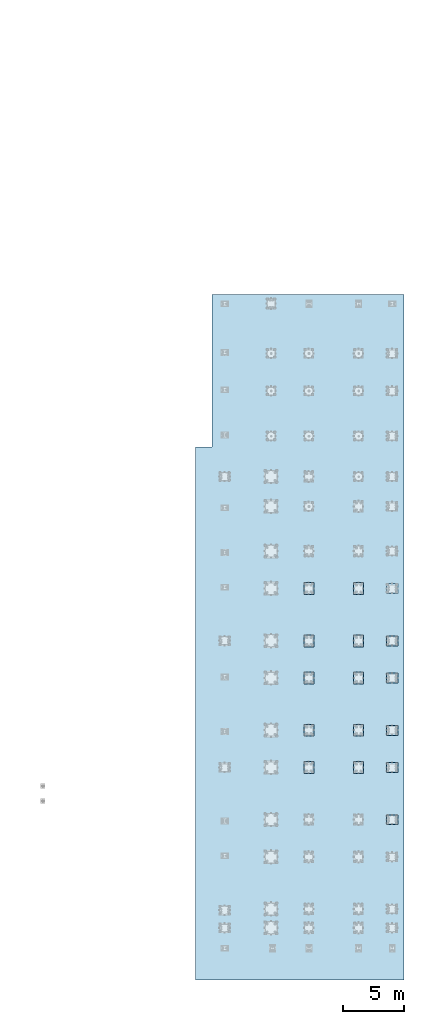
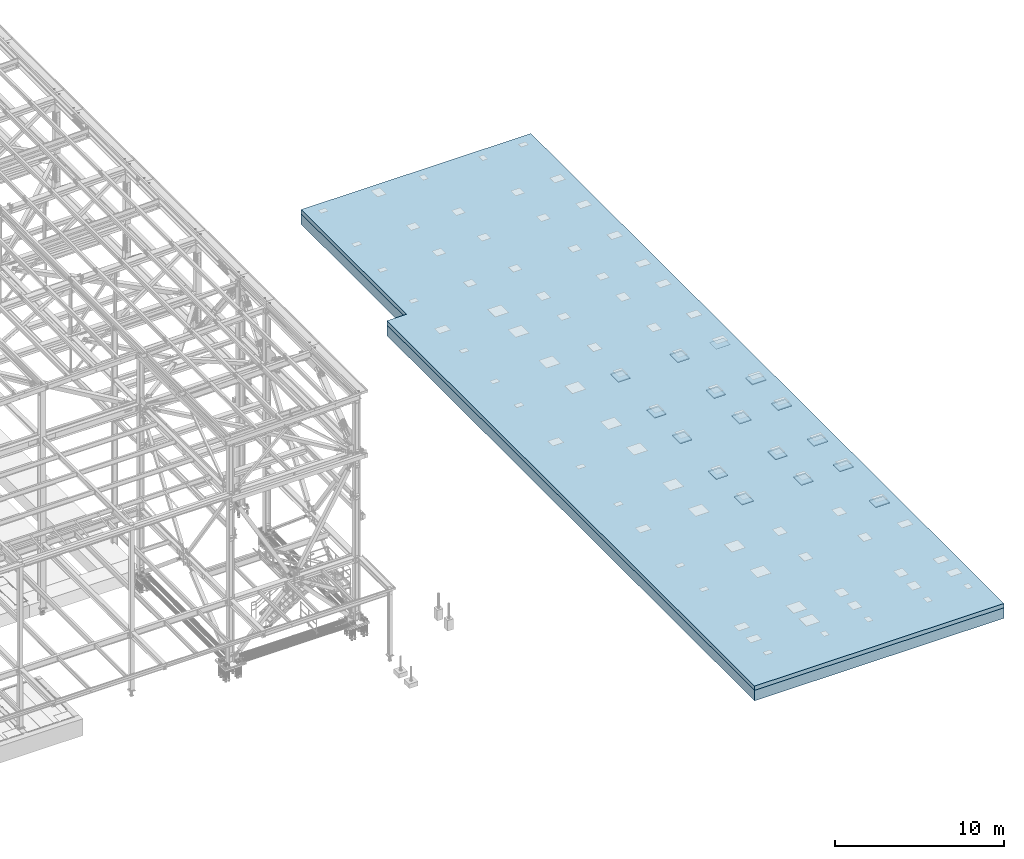
# One storey, part 3001 of 3843: 31 plates, 2 slabs, 33 elements without a shape of their own.
"""IFC2X3 building model written with IfcOpenShell, lengths in millimetres."""

from ifc_helpers import new_model, si_unit, frame, origin_with_axes, place, context, subcontext, project, spatial, faceted_brep, material, type_object, element, aggregate, save


model = new_model("IFC2X3")

# Units and contexts
model_context = context("Model", 3, precision=1e-05, world=origin_with_axes())
body_context = subcontext(model_context, "Body", "Model", "MODEL_VIEW")
ifc_project = project(units=[si_unit("LENGTHUNIT", "METRE", prefix="MILLI"), si_unit("AREAUNIT", "SQUARE_METRE"), si_unit("VOLUMEUNIT", "CUBIC_METRE"), si_unit("MASSUNIT", "GRAM", prefix="KILO"), si_unit("TIMEUNIT", "SECOND"), si_unit("PLANEANGLEUNIT", "RADIAN"), si_unit("SOLIDANGLEUNIT", "STERADIAN"), si_unit("THERMODYNAMICTEMPERATUREUNIT", "DEGREE_CELSIUS"), si_unit("LUMINOUSINTENSITYUNIT", "LUMEN")], contexts=[model_context])

# Site, building, storey
site_placement = place(None, origin_with_axes())
site = spatial("IfcSite", under=ifc_project, at=site_placement, CompositionType="ELEMENT")
building_placement = place(site_placement, origin_with_axes())
building = spatial("IfcBuilding", under=site, at=building_placement, Name="Undefined", CompositionType="ELEMENT")
storey_placement = place(building_placement, origin_with_axes())
storey = spatial("IfcBuildingStorey", under=building, at=storey_placement, Name="Undefined", CompositionType="ELEMENT", Elevation=0.0)

# Assembly, plate
assembly_1_placement = place(storey_placement, origin_with_axes())
assembly_1 = element("IfcElementAssembly", 1, at=assembly_1_placement, inside=storey, Name="TEMPLATE", AssemblyPlace="NOTDEFINED", PredefinedType="RIGID_FRAME")
ifc_material_1 = material(Name="STEEL/A572-50")
plate_type_1 = type_object("IfcPlateType", PredefinedType="NOTDEFINED")
plate_1_placement = place(assembly_1_placement, frame((119329.2, 29819.6, 29791.025), z_axis=(0.0, -1.0, 0.0), x_axis=(-1.0, 0.0, 0.0)))
plate_1 = element("IfcPlate", 2, at=plate_1_placement, type_object=plate_type_1, material=ifc_material_1, Name="TEMPLATE", context=body_context, shape_type="Brep", body=[
    faceted_brep([(0.0, -3.17499999999927, 0.0), (-1.45519152283669e-11, -3.17499999999927, 812.799999999945), (-1.45519152283669e-11, 3.17499999999927, 812.799999999945), (0.0, 3.17499999999927, 0.0), (965.199999999997, -3.17499999999927, 812.799999999974), (965.199999999997, 3.17499999999927, 812.799999999974), (965.199999999997, -3.17499999999927, 0.0), (965.199999999997, 3.17499999999927, 0.0)], [[[0, 1, 2, 3]], [[1, 4, 5, 2]], [[4, 6, 7, 5]], [[6, 0, 3, 7]], [[5, 7, 3, 2]], [[6, 4, 1, 0]]]),
])
aggregate(assembly_1, [plate_1])

assembly_2_placement = place(storey_placement, origin_with_axes())
assembly_2 = element("IfcElementAssembly", 3, at=assembly_2_placement, inside=storey, Name="TEMPLATE", AssemblyPlace="NOTDEFINED", PredefinedType="RIGID_FRAME")
plate_2_placement = place(assembly_2_placement, frame((119329.2, 25539.7, 29791.025), z_axis=(0.0, -1.0, 0.0), x_axis=(-1.0, 0.0, 0.0)))
plate_2 = element("IfcPlate", 4, at=plate_2_placement, type_object=plate_type_1, material=ifc_material_1, Name="TEMPLATE", context=body_context, shape_type="Brep", body=[
    faceted_brep([(0.0, -3.17499999999927, 0.0), (-1.45519152283669e-11, -3.17499999999927, 812.799999999945), (-1.45519152283669e-11, 3.17499999999927, 812.799999999945), (0.0, 3.17499999999927, 0.0), (965.199999999997, -3.17499999999927, 812.799999999974), (965.199999999997, 3.17499999999927, 812.799999999974), (965.199999999997, -3.17499999999927, 0.0), (965.199999999997, 3.17499999999927, 0.0)], [[[0, 1, 2, 3]], [[1, 4, 5, 2]], [[4, 6, 7, 5]], [[6, 0, 3, 7]], [[5, 7, 3, 2]], [[6, 4, 1, 0]]]),
])
aggregate(assembly_2, [plate_2])

assembly_3_placement = place(storey_placement, origin_with_axes())
assembly_3 = element("IfcElementAssembly", 5, at=assembly_3_placement, inside=storey, Name="TEMPLATE", AssemblyPlace="NOTDEFINED", PredefinedType="RIGID_FRAME")
plate_3_placement = place(assembly_3_placement, frame((119329.2, 22491.7, 29791.025), z_axis=(0.0, -1.0, 0.0), x_axis=(-1.0, 0.0, 0.0)))
plate_3 = element("IfcPlate", 6, at=plate_3_placement, type_object=plate_type_1, material=ifc_material_1, Name="TEMPLATE", context=body_context, shape_type="Brep", body=[
    faceted_brep([(0.0, -3.17499999999927, 0.0), (-1.45519152283669e-11, -3.17499999999927, 812.799999999945), (-1.45519152283669e-11, 3.17499999999927, 812.799999999945), (0.0, 3.17499999999927, 0.0), (965.199999999997, -3.17499999999927, 812.799999999974), (965.199999999997, 3.17499999999927, 812.799999999974), (965.199999999997, -3.17499999999927, 0.0), (965.199999999997, 3.17499999999927, 0.0)], [[[0, 1, 2, 3]], [[1, 4, 5, 2]], [[4, 6, 7, 5]], [[6, 0, 3, 7]], [[5, 7, 3, 2]], [[6, 4, 1, 0]]]),
])
aggregate(assembly_3, [plate_3])

assembly_4_placement = place(storey_placement, origin_with_axes())
assembly_4 = element("IfcElementAssembly", 7, at=assembly_4_placement, inside=storey, Name="TEMPLATE", AssemblyPlace="NOTDEFINED", PredefinedType="RIGID_FRAME")
plate_4_placement = place(assembly_4_placement, frame((119329.2, 18224.5, 29791.025), z_axis=(0.0, -1.0, 0.0), x_axis=(-1.0, 0.0, 0.0)))
plate_4 = element("IfcPlate", 8, at=plate_4_placement, type_object=plate_type_1, material=ifc_material_1, Name="TEMPLATE", context=body_context, shape_type="Brep", body=[
    faceted_brep([(0.0, -3.17499999999927, 0.0), (-1.45519152283669e-11, -3.17499999999927, 812.799999999945), (-1.45519152283669e-11, 3.17499999999927, 812.799999999945), (0.0, 3.17499999999927, 0.0), (965.199999999997, -3.17499999999927, 812.799999999974), (965.199999999997, 3.17499999999927, 812.799999999974), (965.199999999997, -3.17499999999927, 0.0), (965.199999999997, 3.17499999999927, 0.0)], [[[0, 1, 2, 3]], [[1, 4, 5, 2]], [[4, 6, 7, 5]], [[6, 0, 3, 7]], [[5, 7, 3, 2]], [[6, 4, 1, 0]]]),
])
aggregate(assembly_4, [plate_4])

assembly_5_placement = place(storey_placement, origin_with_axes())
assembly_5 = element("IfcElementAssembly", 9, at=assembly_5_placement, inside=storey, Name="TEMPLATE", AssemblyPlace="NOTDEFINED", PredefinedType="RIGID_FRAME")
plate_5_placement = place(assembly_5_placement, frame((119329.2, 15176.5, 29791.025), z_axis=(0.0, -1.0, 0.0), x_axis=(-1.0, 0.0, 0.0)))
plate_5 = element("IfcPlate", 10, at=plate_5_placement, type_object=plate_type_1, material=ifc_material_1, Name="TEMPLATE", context=body_context, shape_type="Brep", body=[
    faceted_brep([(0.0, -3.17499999999927, 0.0), (-1.45519152283669e-11, -3.17499999999927, 812.799999999945), (-1.45519152283669e-11, 3.17499999999927, 812.799999999945), (0.0, 3.17499999999927, 0.0), (965.199999999997, -3.17499999999927, 812.799999999974), (965.199999999997, 3.17499999999927, 812.799999999974), (965.199999999997, -3.17499999999927, 0.0), (965.199999999997, 3.17499999999927, 0.0)], [[[0, 1, 2, 3]], [[1, 4, 5, 2]], [[4, 6, 7, 5]], [[6, 0, 3, 7]], [[5, 7, 3, 2]], [[6, 4, 1, 0]]]),
])
aggregate(assembly_5, [plate_5])

assembly_6_placement = place(storey_placement, origin_with_axes())
assembly_6 = element("IfcElementAssembly", 11, at=assembly_6_placement, inside=storey, Name="TEMPLATE", AssemblyPlace="NOTDEFINED", PredefinedType="RIGID_FRAME")
plate_6_placement = place(assembly_6_placement, frame((119329.2, 10909.3, 29791.025), z_axis=(0.0, -1.0, 0.0), x_axis=(-1.0, 0.0, 0.0)))
plate_6 = element("IfcPlate", 12, at=plate_6_placement, type_object=plate_type_1, material=ifc_material_1, Name="TEMPLATE", context=body_context, shape_type="Brep", body=[
    faceted_brep([(0.0, -3.17499999999927, 0.0), (-1.45519152283669e-11, -3.17499999999927, 812.799999999945), (-1.45519152283669e-11, 3.17499999999927, 812.799999999945), (0.0, 3.17499999999927, 0.0), (965.199999999997, -3.17499999999927, 812.799999999974), (965.199999999997, 3.17499999999927, 812.799999999974), (965.199999999997, -3.17499999999927, 0.0), (965.199999999997, 3.17499999999927, 0.0)], [[[0, 1, 2, 3]], [[1, 4, 5, 2]], [[4, 6, 7, 5]], [[6, 0, 3, 7]], [[5, 7, 3, 2]], [[6, 4, 1, 0]]]),
])
aggregate(assembly_6, [plate_6])

assembly_7_placement = place(storey_placement, origin_with_axes())
assembly_7 = element("IfcElementAssembly", 13, at=assembly_7_placement, inside=storey, Name="TEMPLATE", AssemblyPlace="NOTDEFINED", PredefinedType="RIGID_FRAME")
ifc_material_2 = material(Name="STEEL/A36")
plate_7_placement = place(assembly_7_placement, frame((115697.0, 28930.6, 29791.025), z_axis=(0.0, 1.0, 0.0), x_axis=(1.0, 0.0, 0.0)))
plate_7 = element("IfcPlate", 14, at=plate_7_placement, type_object=plate_type_1, material=ifc_material_2, Name="TEMPLATE", context=body_context, shape_type="Brep", body=[
    faceted_brep([(0.0, -3.17499999999927, 0.0), (-4.36557456851006e-11, -3.17499999999927, 965.200000000004), (-4.36557456851006e-11, 3.17499999999927, 965.200000000004), (0.0, 3.17499999999927, 0.0), (812.799999999974, -3.17499999999927, 965.199999999997), (812.799999999974, 3.17499999999927, 965.199999999997), (812.800000000017, -3.17499999999927, 1.45519152283669e-11), (812.800000000017, 3.17499999999927, 1.45519152283669e-11)], [[[0, 1, 2, 3]], [[1, 4, 5, 2]], [[4, 6, 7, 5]], [[6, 0, 3, 7]], [[5, 7, 3, 2]], [[6, 4, 1, 0]]]),
])
aggregate(assembly_7, [plate_7])

assembly_8_placement = place(storey_placement, origin_with_axes())
assembly_8 = element("IfcElementAssembly", 15, at=assembly_8_placement, inside=storey, Name="TEMPLATE", AssemblyPlace="NOTDEFINED", PredefinedType="RIGID_FRAME")
plate_8_placement = place(assembly_8_placement, frame((115697.0, 24650.7, 29791.025), z_axis=(0.0, 1.0, 0.0), x_axis=(1.0, 0.0, 0.0)))
plate_8 = element("IfcPlate", 16, at=plate_8_placement, type_object=plate_type_1, material=ifc_material_2, Name="TEMPLATE", context=body_context, shape_type="Brep", body=[
    faceted_brep([(0.0, -3.17499999999927, 0.0), (-4.36557456851006e-11, -3.17499999999927, 965.200000000004), (-4.36557456851006e-11, 3.17499999999927, 965.200000000004), (0.0, 3.17499999999927, 0.0), (812.799999999974, -3.17499999999927, 965.199999999997), (812.799999999974, 3.17499999999927, 965.199999999997), (812.800000000017, -3.17499999999927, 1.45519152283669e-11), (812.800000000017, 3.17499999999927, 1.45519152283669e-11)], [[[0, 1, 2, 3]], [[1, 4, 5, 2]], [[4, 6, 7, 5]], [[6, 0, 3, 7]], [[5, 7, 3, 2]], [[6, 4, 1, 0]]]),
])
aggregate(assembly_8, [plate_8])

assembly_9_placement = place(storey_placement, origin_with_axes())
assembly_9 = element("IfcElementAssembly", 17, at=assembly_9_placement, inside=storey, Name="TEMPLATE", AssemblyPlace="NOTDEFINED", PredefinedType="RIGID_FRAME")
plate_9_placement = place(assembly_9_placement, frame((115697.0, 21602.7, 29791.025), z_axis=(0.0, 1.0, 0.0), x_axis=(1.0, 0.0, 0.0)))
plate_9 = element("IfcPlate", 18, at=plate_9_placement, type_object=plate_type_1, material=ifc_material_2, Name="TEMPLATE", context=body_context, shape_type="Brep", body=[
    faceted_brep([(0.0, -3.17499999999927, 0.0), (-4.36557456851006e-11, -3.17499999999927, 965.200000000004), (-4.36557456851006e-11, 3.17499999999927, 965.200000000004), (0.0, 3.17499999999927, 0.0), (812.799999999974, -3.17499999999927, 965.199999999997), (812.799999999974, 3.17499999999927, 965.199999999997), (812.800000000017, -3.17499999999927, 1.45519152283669e-11), (812.800000000017, 3.17499999999927, 1.45519152283669e-11)], [[[0, 1, 2, 3]], [[1, 4, 5, 2]], [[4, 6, 7, 5]], [[6, 0, 3, 7]], [[5, 7, 3, 2]], [[6, 4, 1, 0]]]),
])
aggregate(assembly_9, [plate_9])

assembly_10_placement = place(storey_placement, origin_with_axes())
assembly_10 = element("IfcElementAssembly", 19, at=assembly_10_placement, inside=storey, Name="TEMPLATE", AssemblyPlace="NOTDEFINED", PredefinedType="RIGID_FRAME")
plate_10_placement = place(assembly_10_placement, frame((115697.0, 17335.5, 29791.025), z_axis=(0.0, 1.0, 0.0), x_axis=(1.0, 0.0, 0.0)))
plate_10 = element("IfcPlate", 20, at=plate_10_placement, type_object=plate_type_1, material=ifc_material_2, Name="TEMPLATE", context=body_context, shape_type="Brep", body=[
    faceted_brep([(0.0, -3.17499999999927, 0.0), (-4.36557456851006e-11, -3.17499999999927, 965.200000000004), (-4.36557456851006e-11, 3.17499999999927, 965.200000000004), (0.0, 3.17499999999927, 0.0), (812.799999999974, -3.17499999999927, 965.199999999997), (812.799999999974, 3.17499999999927, 965.199999999997), (812.800000000017, -3.17499999999927, 1.45519152283669e-11), (812.800000000017, 3.17499999999927, 1.45519152283669e-11)], [[[0, 1, 2, 3]], [[1, 4, 5, 2]], [[4, 6, 7, 5]], [[6, 0, 3, 7]], [[5, 7, 3, 2]], [[6, 4, 1, 0]]]),
])
aggregate(assembly_10, [plate_10])

assembly_11_placement = place(storey_placement, origin_with_axes())
assembly_11 = element("IfcElementAssembly", 21, at=assembly_11_placement, inside=storey, Name="TEMPLATE", AssemblyPlace="NOTDEFINED", PredefinedType="RIGID_FRAME")
plate_11_placement = place(assembly_11_placement, frame((115697.0, 14287.5, 29791.025), z_axis=(0.0, 1.0, 0.0), x_axis=(1.0, 0.0, 0.0)))
plate_11 = element("IfcPlate", 22, at=plate_11_placement, type_object=plate_type_1, material=ifc_material_2, Name="TEMPLATE", context=body_context, shape_type="Brep", body=[
    faceted_brep([(0.0, -3.17499999999927, 0.0), (-4.36557456851006e-11, -3.17499999999927, 965.200000000004), (-4.36557456851006e-11, 3.17499999999927, 965.200000000004), (0.0, 3.17499999999927, 0.0), (812.799999999974, -3.17499999999927, 965.199999999997), (812.799999999974, 3.17499999999927, 965.199999999997), (812.800000000017, -3.17499999999927, 1.45519152283669e-11), (812.800000000017, 3.17499999999927, 1.45519152283669e-11)], [[[0, 1, 2, 3]], [[1, 4, 5, 2]], [[4, 6, 7, 5]], [[6, 0, 3, 7]], [[5, 7, 3, 2]], [[6, 4, 1, 0]]]),
])
aggregate(assembly_11, [plate_11])

assembly_12_placement = place(storey_placement, origin_with_axes())
assembly_12 = element("IfcElementAssembly", 23, at=assembly_12_placement, inside=storey, Name="TEMPLATE", AssemblyPlace="NOTDEFINED", PredefinedType="RIGID_FRAME")
plate_12_placement = place(assembly_12_placement, frame((111633.0, 28930.6, 29791.025), z_axis=(0.0, 1.0, 0.0), x_axis=(1.0, 0.0, 0.0)))
plate_12 = element("IfcPlate", 24, at=plate_12_placement, type_object=plate_type_1, material=ifc_material_2, Name="TEMPLATE", context=body_context, shape_type="Brep", body=[
    faceted_brep([(0.0, -3.17499999999927, 0.0), (-4.36557456851006e-11, -3.17499999999927, 965.200000000004), (-4.36557456851006e-11, 3.17499999999927, 965.200000000004), (0.0, 3.17499999999927, 0.0), (812.799999999974, -3.17499999999927, 965.199999999997), (812.799999999974, 3.17499999999927, 965.199999999997), (812.800000000017, -3.17499999999927, 1.45519152283669e-11), (812.800000000017, 3.17499999999927, 1.45519152283669e-11)], [[[0, 1, 2, 3]], [[1, 4, 5, 2]], [[4, 6, 7, 5]], [[6, 0, 3, 7]], [[5, 7, 3, 2]], [[6, 4, 1, 0]]]),
])
aggregate(assembly_12, [plate_12])

assembly_13_placement = place(storey_placement, origin_with_axes())
assembly_13 = element("IfcElementAssembly", 25, at=assembly_13_placement, inside=storey, Name="TEMPLATE", AssemblyPlace="NOTDEFINED", PredefinedType="RIGID_FRAME")
plate_13_placement = place(assembly_13_placement, frame((111633.0, 24650.7, 29791.025), z_axis=(0.0, 1.0, 0.0), x_axis=(1.0, 0.0, 0.0)))
plate_13 = element("IfcPlate", 26, at=plate_13_placement, type_object=plate_type_1, material=ifc_material_2, Name="TEMPLATE", context=body_context, shape_type="Brep", body=[
    faceted_brep([(0.0, -3.17499999999927, 0.0), (-4.36557456851006e-11, -3.17499999999927, 965.200000000004), (-4.36557456851006e-11, 3.17499999999927, 965.200000000004), (0.0, 3.17499999999927, 0.0), (812.799999999974, -3.17499999999927, 965.199999999997), (812.799999999974, 3.17499999999927, 965.199999999997), (812.800000000017, -3.17499999999927, 1.45519152283669e-11), (812.800000000017, 3.17499999999927, 1.45519152283669e-11)], [[[0, 1, 2, 3]], [[1, 4, 5, 2]], [[4, 6, 7, 5]], [[6, 0, 3, 7]], [[5, 7, 3, 2]], [[6, 4, 1, 0]]]),
])
aggregate(assembly_13, [plate_13])

assembly_14_placement = place(storey_placement, origin_with_axes())
assembly_14 = element("IfcElementAssembly", 27, at=assembly_14_placement, inside=storey, Name="TEMPLATE", AssemblyPlace="NOTDEFINED", PredefinedType="RIGID_FRAME")
plate_14_placement = place(assembly_14_placement, frame((111633.0, 21602.7, 29791.025), z_axis=(0.0, 1.0, 0.0), x_axis=(1.0, 0.0, 0.0)))
plate_14 = element("IfcPlate", 28, at=plate_14_placement, type_object=plate_type_1, material=ifc_material_2, Name="TEMPLATE", context=body_context, shape_type="Brep", body=[
    faceted_brep([(0.0, -3.17499999999927, 0.0), (-4.36557456851006e-11, -3.17499999999927, 965.200000000004), (-4.36557456851006e-11, 3.17499999999927, 965.200000000004), (0.0, 3.17499999999927, 0.0), (812.799999999974, -3.17499999999927, 965.199999999997), (812.799999999974, 3.17499999999927, 965.199999999997), (812.800000000017, -3.17499999999927, 1.45519152283669e-11), (812.800000000017, 3.17499999999927, 1.45519152283669e-11)], [[[0, 1, 2, 3]], [[1, 4, 5, 2]], [[4, 6, 7, 5]], [[6, 0, 3, 7]], [[5, 7, 3, 2]], [[6, 4, 1, 0]]]),
])
aggregate(assembly_14, [plate_14])

assembly_15_placement = place(storey_placement, origin_with_axes())
assembly_15 = element("IfcElementAssembly", 29, at=assembly_15_placement, inside=storey, Name="TEMPLATE", AssemblyPlace="NOTDEFINED", PredefinedType="RIGID_FRAME")
plate_15_placement = place(assembly_15_placement, frame((111633.0, 17335.5, 29791.025), z_axis=(0.0, 1.0, 0.0), x_axis=(1.0, 0.0, 0.0)))
plate_15 = element("IfcPlate", 30, at=plate_15_placement, type_object=plate_type_1, material=ifc_material_2, Name="TEMPLATE", context=body_context, shape_type="Brep", body=[
    faceted_brep([(0.0, -3.17499999999927, 0.0), (-4.36557456851006e-11, -3.17499999999927, 965.200000000004), (-4.36557456851006e-11, 3.17499999999927, 965.200000000004), (0.0, 3.17499999999927, 0.0), (812.799999999974, -3.17499999999927, 965.199999999997), (812.799999999974, 3.17499999999927, 965.199999999997), (812.800000000017, -3.17499999999927, 1.45519152283669e-11), (812.800000000017, 3.17499999999927, 1.45519152283669e-11)], [[[0, 1, 2, 3]], [[1, 4, 5, 2]], [[4, 6, 7, 5]], [[6, 0, 3, 7]], [[5, 7, 3, 2]], [[6, 4, 1, 0]]]),
])
aggregate(assembly_15, [plate_15])

assembly_16_placement = place(storey_placement, origin_with_axes())
assembly_16 = element("IfcElementAssembly", 31, at=assembly_16_placement, inside=storey, Name="TEMPLATE", AssemblyPlace="NOTDEFINED", PredefinedType="RIGID_FRAME")
plate_16_placement = place(assembly_16_placement, frame((111633.0, 14287.5, 29791.025), z_axis=(0.0, 1.0, 0.0), x_axis=(1.0, 0.0, 0.0)))
plate_16 = element("IfcPlate", 32, at=plate_16_placement, type_object=plate_type_1, material=ifc_material_2, Name="TEMPLATE", context=body_context, shape_type="Brep", body=[
    faceted_brep([(0.0, -3.17499999999927, 0.0), (-4.36557456851006e-11, -3.17499999999927, 965.200000000004), (-4.36557456851006e-11, 3.17499999999927, 965.200000000004), (0.0, 3.17499999999927, 0.0), (812.799999999974, -3.17499999999927, 965.199999999997), (812.799999999974, 3.17499999999927, 965.199999999997), (812.800000000017, -3.17499999999927, 1.45519152283669e-11), (812.800000000017, 3.17499999999927, 1.45519152283669e-11)], [[[0, 1, 2, 3]], [[1, 4, 5, 2]], [[4, 6, 7, 5]], [[6, 0, 3, 7]], [[5, 7, 3, 2]], [[6, 4, 1, 0]]]),
])
aggregate(assembly_16, [plate_16])

assembly_17_placement = place(storey_placement, origin_with_axes())
assembly_17 = element("IfcElementAssembly", 33, at=assembly_17_placement, inside=storey, Name="EMBED_PLATE", AssemblyPlace="NOTDEFINED", PredefinedType="RIGID_FRAME")
plate_type_2 = type_object("IfcPlateType", PredefinedType="NOTDEFINED")
plate_17_placement = place(assembly_17_placement, frame((118364.0, 25539.7, 29825.95), z_axis=(1.0, 0.0, 0.0), x_axis=(0.0, -1.0, 0.0)))
plate_17 = element("IfcPlate", 34, at=plate_17_placement, type_object=plate_type_2, material=ifc_material_1, Name="EMBED_PLATE", context=body_context, shape_type="Brep", body=[
    faceted_brep([(0.0, -38.0999999999985, 0.0), (0.0, -38.0999999999985, 965.199999999983), (0.0, 38.0999999999985, 965.199999999983), (0.0, 38.0999999999985, 0.0), (812.800000000003, -38.0999999999985, 965.199999999983), (812.800000000003, 38.0999999999985, 965.199999999983), (812.800000000003, -38.0999999999985, 0.0), (812.800000000003, 38.0999999999985, 0.0)], [[[0, 1, 2, 3]], [[1, 4, 5, 2]], [[4, 6, 7, 5]], [[6, 0, 3, 7]], [[5, 7, 3, 2]], [[6, 4, 1, 0]]]),
])
aggregate(assembly_17, [plate_17])

assembly_18_placement = place(storey_placement, origin_with_axes())
assembly_18 = element("IfcElementAssembly", 35, at=assembly_18_placement, inside=storey, Name="EMBED_PLATE", AssemblyPlace="NOTDEFINED", PredefinedType="RIGID_FRAME")
plate_18_placement = place(assembly_18_placement, frame((118364.0, 22491.7, 29825.95), z_axis=(1.0, 0.0, 0.0), x_axis=(0.0, -1.0, 0.0)))
plate_18 = element("IfcPlate", 36, at=plate_18_placement, type_object=plate_type_2, material=ifc_material_1, Name="EMBED_PLATE", context=body_context, shape_type="Brep", body=[
    faceted_brep([(0.0, -38.0999999999985, 0.0), (0.0, -38.0999999999985, 965.199999999983), (0.0, 38.0999999999985, 965.199999999983), (0.0, 38.0999999999985, 0.0), (812.800000000003, -38.0999999999985, 965.199999999983), (812.800000000003, 38.0999999999985, 965.199999999983), (812.800000000003, -38.0999999999985, 0.0), (812.800000000003, 38.0999999999985, 0.0)], [[[0, 1, 2, 3]], [[1, 4, 5, 2]], [[4, 6, 7, 5]], [[6, 0, 3, 7]], [[5, 7, 3, 2]], [[6, 4, 1, 0]]]),
])
aggregate(assembly_18, [plate_18])

assembly_19_placement = place(storey_placement, origin_with_axes())
assembly_19 = element("IfcElementAssembly", 37, at=assembly_19_placement, inside=storey, Name="EMBED_PLATE", AssemblyPlace="NOTDEFINED", PredefinedType="RIGID_FRAME")
plate_19_placement = place(assembly_19_placement, frame((118364.0, 18224.5, 29825.95), z_axis=(1.0, 0.0, 0.0), x_axis=(0.0, -1.0, 0.0)))
plate_19 = element("IfcPlate", 38, at=plate_19_placement, type_object=plate_type_2, material=ifc_material_1, Name="EMBED_PLATE", context=body_context, shape_type="Brep", body=[
    faceted_brep([(0.0, -38.0999999999985, 0.0), (0.0, -38.0999999999985, 965.199999999983), (0.0, 38.0999999999985, 965.199999999983), (0.0, 38.0999999999985, 0.0), (812.800000000003, -38.0999999999985, 965.199999999983), (812.800000000003, 38.0999999999985, 965.199999999983), (812.800000000003, -38.0999999999985, 0.0), (812.800000000003, 38.0999999999985, 0.0)], [[[0, 1, 2, 3]], [[1, 4, 5, 2]], [[4, 6, 7, 5]], [[6, 0, 3, 7]], [[5, 7, 3, 2]], [[6, 4, 1, 0]]]),
])
aggregate(assembly_19, [plate_19])

assembly_20_placement = place(storey_placement, origin_with_axes())
assembly_20 = element("IfcElementAssembly", 39, at=assembly_20_placement, inside=storey, Name="EMBED_PLATE", AssemblyPlace="NOTDEFINED", PredefinedType="RIGID_FRAME")
plate_20_placement = place(assembly_20_placement, frame((118364.0, 15176.5, 29825.95), z_axis=(1.0, 0.0, 0.0), x_axis=(0.0, -1.0, 0.0)))
plate_20 = element("IfcPlate", 40, at=plate_20_placement, type_object=plate_type_2, material=ifc_material_1, Name="EMBED_PLATE", context=body_context, shape_type="Brep", body=[
    faceted_brep([(0.0, -38.0999999999985, 0.0), (0.0, -38.0999999999985, 965.199999999983), (0.0, 38.0999999999985, 965.199999999983), (0.0, 38.0999999999985, 0.0), (812.800000000003, -38.0999999999985, 965.199999999983), (812.800000000003, 38.0999999999985, 965.199999999983), (812.800000000003, -38.0999999999985, 0.0), (812.800000000003, 38.0999999999985, 0.0)], [[[0, 1, 2, 3]], [[1, 4, 5, 2]], [[4, 6, 7, 5]], [[6, 0, 3, 7]], [[5, 7, 3, 2]], [[6, 4, 1, 0]]]),
])
aggregate(assembly_20, [plate_20])

assembly_21_placement = place(storey_placement, origin_with_axes())
assembly_21 = element("IfcElementAssembly", 41, at=assembly_21_placement, inside=storey, Name="EMBED_PLATE", AssemblyPlace="NOTDEFINED", PredefinedType="RIGID_FRAME")
plate_21_placement = place(assembly_21_placement, frame((118364.0, 10909.3, 29825.95), z_axis=(1.0, 0.0, 0.0), x_axis=(0.0, -1.0, 0.0)))
plate_21 = element("IfcPlate", 42, at=plate_21_placement, type_object=plate_type_2, material=ifc_material_1, Name="EMBED_PLATE", context=body_context, shape_type="Brep", body=[
    faceted_brep([(0.0, -38.0999999999985, 0.0), (0.0, -38.0999999999985, 965.199999999983), (0.0, 38.0999999999985, 965.199999999983), (0.0, 38.0999999999985, 0.0), (812.800000000003, -38.0999999999985, 965.199999999983), (812.800000000003, 38.0999999999985, 965.199999999983), (812.800000000003, -38.0999999999985, 0.0), (812.800000000003, 38.0999999999985, 0.0)], [[[0, 1, 2, 3]], [[1, 4, 5, 2]], [[4, 6, 7, 5]], [[6, 0, 3, 7]], [[5, 7, 3, 2]], [[6, 4, 1, 0]]]),
])
aggregate(assembly_21, [plate_21])

assembly_22_placement = place(storey_placement, origin_with_axes())
assembly_22 = element("IfcElementAssembly", 43, at=assembly_22_placement, inside=storey, Name="EMBED_PLATE", AssemblyPlace="NOTDEFINED", PredefinedType="RIGID_FRAME")
plate_22_placement = place(assembly_22_placement, frame((115697.0, 28930.6, 29825.95), z_axis=(0.0, 1.0, 0.0), x_axis=(1.0, 0.0, 0.0)))
plate_22 = element("IfcPlate", 44, at=plate_22_placement, type_object=plate_type_2, material=ifc_material_1, Name="EMBED_PLATE", context=body_context, shape_type="Brep", body=[
    faceted_brep([(0.0, -38.0999999999985, 0.0), (0.0, -38.0999999999985, 965.199999999983), (0.0, 38.0999999999985, 965.199999999983), (0.0, 38.0999999999985, 0.0), (812.800000000003, -38.0999999999985, 965.199999999983), (812.800000000003, 38.0999999999985, 965.199999999983), (812.800000000003, -38.0999999999985, 0.0), (812.800000000003, 38.0999999999985, 0.0)], [[[0, 1, 2, 3]], [[1, 4, 5, 2]], [[4, 6, 7, 5]], [[6, 0, 3, 7]], [[5, 7, 3, 2]], [[6, 4, 1, 0]]]),
])
aggregate(assembly_22, [plate_22])

assembly_23_placement = place(storey_placement, origin_with_axes())
assembly_23 = element("IfcElementAssembly", 45, at=assembly_23_placement, inside=storey, Name="EMBED_PLATE", AssemblyPlace="NOTDEFINED", PredefinedType="RIGID_FRAME")
plate_23_placement = place(assembly_23_placement, frame((115697.0, 24650.7, 29825.95), z_axis=(0.0, 1.0, 0.0), x_axis=(1.0, 0.0, 0.0)))
plate_23 = element("IfcPlate", 46, at=plate_23_placement, type_object=plate_type_2, material=ifc_material_1, Name="EMBED_PLATE", context=body_context, shape_type="Brep", body=[
    faceted_brep([(0.0, -38.0999999999985, 0.0), (0.0, -38.0999999999985, 965.199999999983), (0.0, 38.0999999999985, 965.199999999983), (0.0, 38.0999999999985, 0.0), (812.800000000003, -38.0999999999985, 965.199999999983), (812.800000000003, 38.0999999999985, 965.199999999983), (812.800000000003, -38.0999999999985, 0.0), (812.800000000003, 38.0999999999985, 0.0)], [[[0, 1, 2, 3]], [[1, 4, 5, 2]], [[4, 6, 7, 5]], [[6, 0, 3, 7]], [[5, 7, 3, 2]], [[6, 4, 1, 0]]]),
])
aggregate(assembly_23, [plate_23])

assembly_24_placement = place(storey_placement, origin_with_axes())
assembly_24 = element("IfcElementAssembly", 47, at=assembly_24_placement, inside=storey, Name="EMBED_PLATE", AssemblyPlace="NOTDEFINED", PredefinedType="RIGID_FRAME")
plate_24_placement = place(assembly_24_placement, frame((115697.0, 21602.7, 29825.95), z_axis=(0.0, 1.0, 0.0), x_axis=(1.0, 0.0, 0.0)))
plate_24 = element("IfcPlate", 48, at=plate_24_placement, type_object=plate_type_2, material=ifc_material_1, Name="EMBED_PLATE", context=body_context, shape_type="Brep", body=[
    faceted_brep([(0.0, -38.0999999999985, 0.0), (0.0, -38.0999999999985, 965.199999999983), (0.0, 38.0999999999985, 965.199999999983), (0.0, 38.0999999999985, 0.0), (812.800000000003, -38.0999999999985, 965.199999999983), (812.800000000003, 38.0999999999985, 965.199999999983), (812.800000000003, -38.0999999999985, 0.0), (812.800000000003, 38.0999999999985, 0.0)], [[[0, 1, 2, 3]], [[1, 4, 5, 2]], [[4, 6, 7, 5]], [[6, 0, 3, 7]], [[5, 7, 3, 2]], [[6, 4, 1, 0]]]),
])
aggregate(assembly_24, [plate_24])

assembly_25_placement = place(storey_placement, origin_with_axes())
assembly_25 = element("IfcElementAssembly", 49, at=assembly_25_placement, inside=storey, Name="EMBED_PLATE", AssemblyPlace="NOTDEFINED", PredefinedType="RIGID_FRAME")
plate_25_placement = place(assembly_25_placement, frame((115697.0, 17335.5, 29825.95), z_axis=(0.0, 1.0, 0.0), x_axis=(1.0, 0.0, 0.0)))
plate_25 = element("IfcPlate", 50, at=plate_25_placement, type_object=plate_type_2, material=ifc_material_1, Name="EMBED_PLATE", context=body_context, shape_type="Brep", body=[
    faceted_brep([(0.0, -38.0999999999985, 0.0), (0.0, -38.0999999999985, 965.199999999983), (0.0, 38.0999999999985, 965.199999999983), (0.0, 38.0999999999985, 0.0), (812.800000000003, -38.0999999999985, 965.199999999983), (812.800000000003, 38.0999999999985, 965.199999999983), (812.800000000003, -38.0999999999985, 0.0), (812.800000000003, 38.0999999999985, 0.0)], [[[0, 1, 2, 3]], [[1, 4, 5, 2]], [[4, 6, 7, 5]], [[6, 0, 3, 7]], [[5, 7, 3, 2]], [[6, 4, 1, 0]]]),
])
aggregate(assembly_25, [plate_25])

assembly_26_placement = place(storey_placement, origin_with_axes())
assembly_26 = element("IfcElementAssembly", 51, at=assembly_26_placement, inside=storey, Name="EMBED_PLATE", AssemblyPlace="NOTDEFINED", PredefinedType="RIGID_FRAME")
plate_26_placement = place(assembly_26_placement, frame((115697.0, 14287.5, 29825.95), z_axis=(0.0, 1.0, 0.0), x_axis=(1.0, 0.0, 0.0)))
plate_26 = element("IfcPlate", 52, at=plate_26_placement, type_object=plate_type_2, material=ifc_material_1, Name="EMBED_PLATE", context=body_context, shape_type="Brep", body=[
    faceted_brep([(0.0, -38.0999999999985, 0.0), (0.0, -38.0999999999985, 965.199999999983), (0.0, 38.0999999999985, 965.199999999983), (0.0, 38.0999999999985, 0.0), (812.800000000003, -38.0999999999985, 965.199999999983), (812.800000000003, 38.0999999999985, 965.199999999983), (812.800000000003, -38.0999999999985, 0.0), (812.800000000003, 38.0999999999985, 0.0)], [[[0, 1, 2, 3]], [[1, 4, 5, 2]], [[4, 6, 7, 5]], [[6, 0, 3, 7]], [[5, 7, 3, 2]], [[6, 4, 1, 0]]]),
])
aggregate(assembly_26, [plate_26])

assembly_27_placement = place(storey_placement, origin_with_axes())
assembly_27 = element("IfcElementAssembly", 53, at=assembly_27_placement, inside=storey, Name="EMBED_PLATE", AssemblyPlace="NOTDEFINED", PredefinedType="RIGID_FRAME")
plate_27_placement = place(assembly_27_placement, frame((111633.0, 28930.6, 29825.95), z_axis=(0.0, 1.0, 0.0), x_axis=(1.0, 0.0, 0.0)))
plate_27 = element("IfcPlate", 54, at=plate_27_placement, type_object=plate_type_2, material=ifc_material_1, Name="EMBED_PLATE", context=body_context, shape_type="Brep", body=[
    faceted_brep([(0.0, -38.0999999999985, 0.0), (0.0, -38.0999999999985, 965.199999999983), (0.0, 38.0999999999985, 965.199999999983), (0.0, 38.0999999999985, 0.0), (812.800000000003, -38.0999999999985, 965.199999999983), (812.800000000003, 38.0999999999985, 965.199999999983), (812.800000000003, -38.0999999999985, 0.0), (812.800000000003, 38.0999999999985, 0.0)], [[[0, 1, 2, 3]], [[1, 4, 5, 2]], [[4, 6, 7, 5]], [[6, 0, 3, 7]], [[5, 7, 3, 2]], [[6, 4, 1, 0]]]),
])
aggregate(assembly_27, [plate_27])

assembly_28_placement = place(storey_placement, origin_with_axes())
assembly_28 = element("IfcElementAssembly", 55, at=assembly_28_placement, inside=storey, Name="EMBED_PLATE", AssemblyPlace="NOTDEFINED", PredefinedType="RIGID_FRAME")
plate_28_placement = place(assembly_28_placement, frame((111633.0, 24650.7, 29825.95), z_axis=(0.0, 1.0, 0.0), x_axis=(1.0, 0.0, 0.0)))
plate_28 = element("IfcPlate", 56, at=plate_28_placement, type_object=plate_type_2, material=ifc_material_1, Name="EMBED_PLATE", context=body_context, shape_type="Brep", body=[
    faceted_brep([(0.0, -38.0999999999985, 0.0), (0.0, -38.0999999999985, 965.199999999983), (0.0, 38.0999999999985, 965.199999999983), (0.0, 38.0999999999985, 0.0), (812.800000000003, -38.0999999999985, 965.199999999983), (812.800000000003, 38.0999999999985, 965.199999999983), (812.800000000003, -38.0999999999985, 0.0), (812.800000000003, 38.0999999999985, 0.0)], [[[0, 1, 2, 3]], [[1, 4, 5, 2]], [[4, 6, 7, 5]], [[6, 0, 3, 7]], [[5, 7, 3, 2]], [[6, 4, 1, 0]]]),
])
aggregate(assembly_28, [plate_28])

assembly_29_placement = place(storey_placement, origin_with_axes())
assembly_29 = element("IfcElementAssembly", 57, at=assembly_29_placement, inside=storey, Name="EMBED_PLATE", AssemblyPlace="NOTDEFINED", PredefinedType="RIGID_FRAME")
plate_29_placement = place(assembly_29_placement, frame((111633.0, 21602.7, 29825.95), z_axis=(0.0, 1.0, 0.0), x_axis=(1.0, 0.0, 0.0)))
plate_29 = element("IfcPlate", 58, at=plate_29_placement, type_object=plate_type_2, material=ifc_material_1, Name="EMBED_PLATE", context=body_context, shape_type="Brep", body=[
    faceted_brep([(0.0, -38.0999999999985, 0.0), (0.0, -38.0999999999985, 965.199999999983), (0.0, 38.0999999999985, 965.199999999983), (0.0, 38.0999999999985, 0.0), (812.800000000003, -38.0999999999985, 965.199999999983), (812.800000000003, 38.0999999999985, 965.199999999983), (812.800000000003, -38.0999999999985, 0.0), (812.800000000003, 38.0999999999985, 0.0)], [[[0, 1, 2, 3]], [[1, 4, 5, 2]], [[4, 6, 7, 5]], [[6, 0, 3, 7]], [[5, 7, 3, 2]], [[6, 4, 1, 0]]]),
])
aggregate(assembly_29, [plate_29])

assembly_30_placement = place(storey_placement, origin_with_axes())
assembly_30 = element("IfcElementAssembly", 59, at=assembly_30_placement, inside=storey, Name="EMBED_PLATE", AssemblyPlace="NOTDEFINED", PredefinedType="RIGID_FRAME")
plate_30_placement = place(assembly_30_placement, frame((111633.0, 17335.5, 29825.95), z_axis=(0.0, 1.0, 0.0), x_axis=(1.0, 0.0, 0.0)))
plate_30 = element("IfcPlate", 60, at=plate_30_placement, type_object=plate_type_2, material=ifc_material_1, Name="EMBED_PLATE", context=body_context, shape_type="Brep", body=[
    faceted_brep([(0.0, -38.0999999999985, 0.0), (0.0, -38.0999999999985, 965.199999999983), (0.0, 38.0999999999985, 965.199999999983), (0.0, 38.0999999999985, 0.0), (812.800000000003, -38.0999999999985, 965.199999999983), (812.800000000003, 38.0999999999985, 965.199999999983), (812.800000000003, -38.0999999999985, 0.0), (812.800000000003, 38.0999999999985, 0.0)], [[[0, 1, 2, 3]], [[1, 4, 5, 2]], [[4, 6, 7, 5]], [[6, 0, 3, 7]], [[5, 7, 3, 2]], [[6, 4, 1, 0]]]),
])
aggregate(assembly_30, [plate_30])

assembly_31_placement = place(storey_placement, origin_with_axes())
assembly_31 = element("IfcElementAssembly", 61, at=assembly_31_placement, inside=storey, Name="EMBED_PLATE", AssemblyPlace="NOTDEFINED", PredefinedType="RIGID_FRAME")
plate_31_placement = place(assembly_31_placement, frame((111633.0, 14287.5, 29825.95), z_axis=(0.0, 1.0, 0.0), x_axis=(1.0, 0.0, 0.0)))
plate_31 = element("IfcPlate", 62, at=plate_31_placement, type_object=plate_type_2, material=ifc_material_1, Name="EMBED_PLATE", context=body_context, shape_type="Brep", body=[
    faceted_brep([(0.0, -38.0999999999985, 0.0), (0.0, -38.0999999999985, 965.199999999983), (0.0, 38.0999999999985, 965.199999999983), (0.0, 38.0999999999985, 0.0), (812.800000000003, -38.0999999999985, 965.199999999983), (812.800000000003, 38.0999999999985, 965.199999999983), (812.800000000003, -38.0999999999985, 0.0), (812.800000000003, 38.0999999999985, 0.0)], [[[0, 1, 2, 3]], [[1, 4, 5, 2]], [[4, 6, 7, 5]], [[6, 0, 3, 7]], [[5, 7, 3, 2]], [[6, 4, 1, 0]]]),
])
aggregate(assembly_31, [plate_31])

# Assembly, slab
assembly_32_placement = place(storey_placement, origin_with_axes())
assembly_32 = element("IfcElementAssembly", 63, at=assembly_32_placement, inside=storey, Name="SLAB", AssemblyPlace="NOTDEFINED", PredefinedType="REINFORCEMENT_UNIT")
ifc_material_3 = material(Name="CONCRETE/3000")
slab_type_1 = type_object("IfcSlabType", PredefinedType="NOTDEFINED")
slab_1_placement = place(assembly_32_placement, frame((119811.8, 53479.7, 29381.45), z_axis=(0.0, -1.0, 0.0), x_axis=(-1.0, 0.0, 0.0)))
slab_1 = element("IfcSlab", 64, at=slab_1_placement, type_object=slab_type_1, material=ifc_material_3, Name="SLAB", PredefinedType="FLOOR", context=body_context, shape_type="Brep", body=[
    faceted_brep([(15722.6, -381.0, 0.0), (15722.6, 381.0, 0.0), (15722.6, 381.0, 12496.8), (15722.6, -381.0, 12496.8), (17068.8, -381.0, 12496.8), (17068.8, 381.0, 12496.8), (0.0, -381.0, 0.0), (0.0, -381.0, 56083.2), (0.0, 381.0, 56083.2), (0.0, 381.0, 0.0), (17068.8, -381.0, 56083.2), (17068.8, 381.0, 56083.2)], [[[0, 1, 2, 3]], [[4, 3, 2, 5]], [[6, 7, 8, 9]], [[7, 10, 11, 8]], [[11, 10, 4, 5]], [[1, 9, 8, 11, 5, 2]], [[6, 9, 1, 0]], [[10, 7, 6, 0, 3, 4]]]),
])
aggregate(assembly_32, [slab_1])

assembly_33_placement = place(storey_placement, origin_with_axes())
assembly_33 = element("IfcElementAssembly", 65, at=assembly_33_placement, inside=storey, Name="SLAB", AssemblyPlace="NOTDEFINED", PredefinedType="REINFORCEMENT_UNIT")
slab_type_2 = type_object("IfcSlabType", PredefinedType="NOTDEFINED")
slab_2_placement = place(assembly_33_placement, frame((119811.8, 53479.7, 29914.85), z_axis=(0.0, -1.0, 0.0), x_axis=(-1.0, 0.0, 0.0)))
slab_2 = element("IfcSlab", 66, at=slab_2_placement, type_object=slab_type_2, material=ifc_material_3, Name="SLAB", PredefinedType="FLOOR", context=body_context, shape_type="Brep", body=[
    faceted_brep([(15722.6, -152.400000000001, 0.0), (15722.6, 152.400000000001, 0.0), (15722.6, 152.400000000001, 12496.8), (15722.6, -152.400000000001, 12496.8), (17068.8, -152.400000000001, 12496.8), (17068.8, 152.400000000001, 12496.8), (0.0, -152.400000000001, 0.0), (0.0, -152.400000000001, 56083.2), (0.0, 152.400000000001, 56083.2), (0.0, 152.400000000001, 0.0), (17068.8, -152.400000000001, 56083.2), (17068.8, 152.400000000001, 56083.2)], [[[0, 1, 2, 3]], [[4, 3, 2, 5]], [[6, 7, 8, 9]], [[7, 10, 11, 8]], [[11, 10, 4, 5]], [[1, 9, 8, 11, 5, 2]], [[6, 9, 1, 0]], [[10, 7, 6, 0, 3, 4]]]),
])
aggregate(assembly_33, [slab_2])

save(model, "model.ifc")
